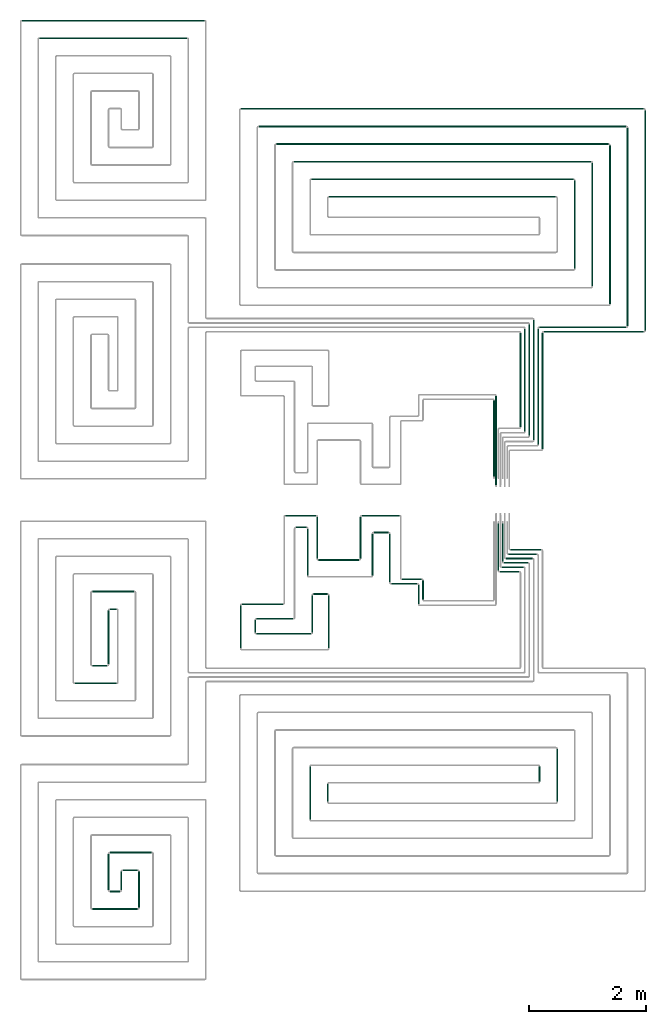
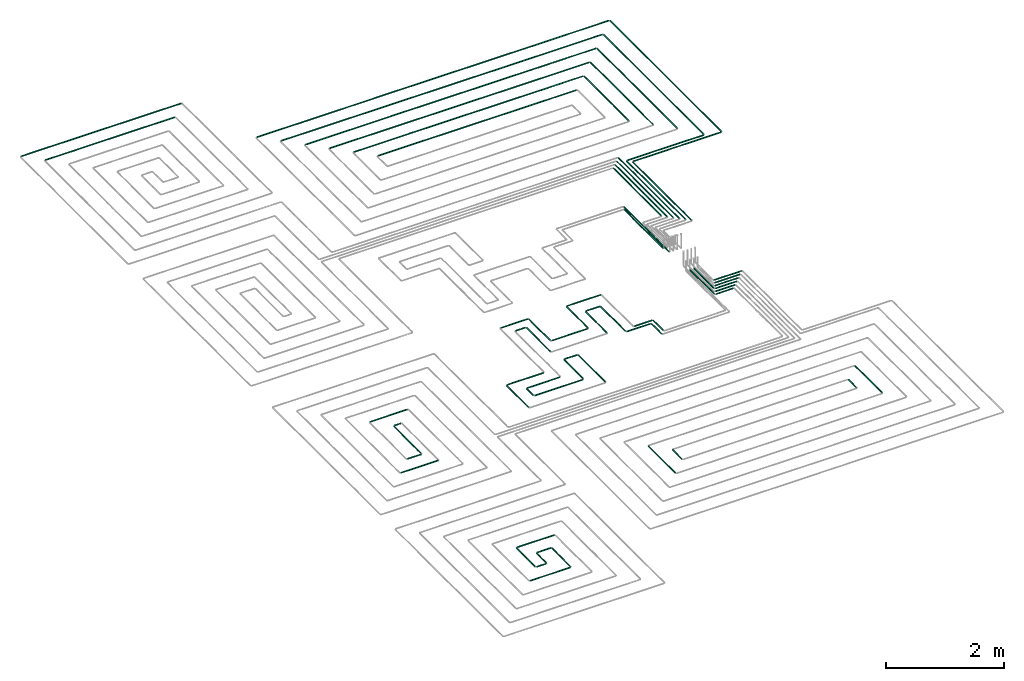
# One storey, part 3 of 12: 69 flow segments.
"""IFC2X3 building model written with IfcOpenShell, lengths in millimetres."""

from ifc_helpers import new_model, entity, si_unit, converted_unit, derived_unit, direction, frame, frame_2d, origin, origin_2d_with_axis, place, context, subcontext, project, spatial, circle, extrude, type_object, element, save


model = new_model("IFC2X3")

# Units and contexts
model_context = context("Model", 3, precision=0.01, world=origin(), true_north=direction((6.12303176911189e-17, 1.0)))
body_context = subcontext(model_context, "Body", "Model", "MODEL_VIEW")
ifc_project = project(units=[si_unit("LENGTHUNIT", "METRE", prefix="MILLI"), si_unit("AREAUNIT", "SQUARE_METRE"), si_unit("VOLUMEUNIT", "CUBIC_METRE"), converted_unit("PLANEANGLEUNIT", "DEGREE", entity("IfcRatioMeasure", 0.0174532925199433), si_unit("PLANEANGLEUNIT", "RADIAN"), dimensions=[0, 0, 0, 0, 0, 0, 0]), si_unit("MASSUNIT", "GRAM", prefix="KILO"), derived_unit("MASSDENSITYUNIT", [(si_unit("MASSUNIT", "GRAM", prefix="KILO"), 1), (si_unit("LENGTHUNIT", "METRE"), -3)]), si_unit("TIMEUNIT", "SECOND"), si_unit("FREQUENCYUNIT", "HERTZ"), si_unit("THERMODYNAMICTEMPERATUREUNIT", "DEGREE_CELSIUS"), derived_unit("THERMALTRANSMITTANCEUNIT", [(si_unit("MASSUNIT", "GRAM", prefix="KILO"), 1), (si_unit("THERMODYNAMICTEMPERATUREUNIT", "KELVIN"), -1), (si_unit("TIMEUNIT", "SECOND"), -3)]), derived_unit("VOLUMETRICFLOWRATEUNIT", [(si_unit("LENGTHUNIT", "METRE"), 3), (si_unit("TIMEUNIT", "SECOND"), -1)]), si_unit("ELECTRICCURRENTUNIT", "AMPERE"), si_unit("ELECTRICVOLTAGEUNIT", "VOLT"), si_unit("POWERUNIT", "WATT"), si_unit("FORCEUNIT", "NEWTON", prefix="KILO"), si_unit("ILLUMINANCEUNIT", "LUX"), si_unit("LUMINOUSFLUXUNIT", "LUMEN"), si_unit("LUMINOUSINTENSITYUNIT", "CANDELA"), derived_unit("USERDEFINED", [(si_unit("MASSUNIT", "GRAM", prefix="KILO"), -1), (si_unit("LENGTHUNIT", "METRE"), -2), (si_unit("TIMEUNIT", "SECOND"), 3), (si_unit("LUMINOUSFLUXUNIT", "LUMEN"), 1)]), derived_unit("LINEARVELOCITYUNIT", [(si_unit("LENGTHUNIT", "METRE"), 1), (si_unit("TIMEUNIT", "SECOND"), -1)]), si_unit("PRESSUREUNIT", "PASCAL"), derived_unit("USERDEFINED", [(si_unit("LENGTHUNIT", "METRE"), -2), (si_unit("MASSUNIT", "GRAM", prefix="KILO"), 1), (si_unit("TIMEUNIT", "SECOND"), -2)])], contexts=[model_context])

# Site, building, storey
site_placement = place(None, origin())
site = spatial("IfcSite", under=ifc_project, at=site_placement, CompositionType="ELEMENT")
building_placement = place(site_placement, origin())
building = spatial("IfcBuilding", under=site, at=building_placement, CompositionType="ELEMENT")
storey_placement = place(building_placement, frame((0.0, 0.0, 12000.0)))
storey = spatial("IfcBuildingStorey", under=building, at=storey_placement, Name="03 Level", CompositionType="ELEMENT", Elevation=12000.0)

# Flow segments
pipe_segment_type = type_object("IfcPipeSegmentType", PredefinedType="NOTDEFINED")
flow_segment_1_placement = place(storey_placement, frame((24021.0090559391, -70269.05691443, -81.5952722359252)))
element("IfcFlowSegment", 1, at=flow_segment_1_placement, inside=storey, type_object=pipe_segment_type, context=body_context, shape_type="SweptSolid", body=[
    extrude(circle(Radius=10.0, at=frame_2d((8.66293703438714e-12, -2.16573425859679e-12), x_axis=(1.0, 0.0))), frame((0.0, 11.5952722359136, 11.595272235918), z_axis=(1.0, 0.0, 0.0), x_axis=(0.0, 1.0, 0.0)), (0.0, 0.0, 1.0), 450.721832403925),
])
flow_segment_2_placement = place(storey_placement, frame((18625.6253473194, -71966.1931086591, -81.5952722359234)))
element("IfcFlowSegment", 2, at=flow_segment_2_placement, inside=storey, type_object=pipe_segment_type, context=body_context, shape_type="SweptSolid", body=[
    extrude(circle(Radius=10.0, at=origin_2d_with_axis()), frame((0.0, 11.5952722359136, 11.5952722359158), z_axis=(1.0, 0.0, 0.0), x_axis=(0.0, 1.0, 0.0)), (0.0, 0.0, 1.0), 718.813282054726),
])
flow_segment_3_placement = place(storey_placement, frame((18925.6253473194, -70402.8348573758, -81.5952722359234)))
element("IfcFlowSegment", 3, at=flow_segment_3_placement, inside=storey, type_object=pipe_segment_type, context=body_context, shape_type="SweptSolid", body=[
    extrude(circle(Radius=10.0, at=origin_2d_with_axis()), frame((0.0, 11.5952722359136, 11.5952722359158), z_axis=(1.0, 0.0, 0.0), x_axis=(0.0, -1.0, 0.0)), (0.0, 0.0, 1.0), 718.813282054721),
])
flow_segment_4_placement = place(storey_placement, frame((19225.6253473194, -70702.8348573758, -81.5952722359234)))
element("IfcFlowSegment", 4, at=flow_segment_4_placement, inside=storey, type_object=pipe_segment_type, context=body_context, shape_type="SweptSolid", body=[
    extrude(circle(Radius=10.0, at=frame_2d((-8.66293703438714e-12, 0.0), x_axis=(1.0, 0.0))), frame((0.0, 11.5952722359136, 11.5952722359158), z_axis=(1.0, 0.0, 0.0), x_axis=(0.0, 1.0, 0.0)), (0.0, 0.0, 1.0), 118.813282054734),
])
flow_segment_5_placement = place(storey_placement, frame((19194.0300750835, -71634.5978364232, -81.5952722359234)))
element("IfcFlowSegment", 5, at=flow_segment_5_placement, inside=storey, type_object=pipe_segment_type, context=body_context, shape_type="SweptSolid", body=[
    extrude(circle(Radius=10.0, at=frame_2d((-2.16573425859679e-12, 0.0), x_axis=(1.0, 0.0))), frame((11.595272235918, 0.0, 11.5952722359158), z_axis=(0.0, 1.0, 0.0), x_axis=(-1.0, 0.0, 0.0)), (0.0, 0.0, 1.0), 923.358251283313),
])
flow_segment_6_placement = place(storey_placement, frame((18925.6253473194, -71666.1931086591, -81.595272235927)))
element("IfcFlowSegment", 6, at=flow_segment_6_placement, inside=storey, type_object=pipe_segment_type, context=body_context, shape_type="SweptSolid", body=[
    extrude(circle(Radius=10.0, at=frame_2d((8.66293703438714e-12, 0.0), x_axis=(1.0, 0.0))), frame((0.0, 11.5952722359136, 11.5952722359158), z_axis=(1.0, 0.0, 0.0), x_axis=(0.0, 1.0, 0.0)), (0.0, 0.0, 1.0), 260.000000000012),
])
flow_segment_7_placement = place(storey_placement, frame((19712.8433571382, -75784.5978364232, -81.5952722359252)))
element("IfcFlowSegment", 7, at=flow_segment_7_placement, inside=storey, type_object=pipe_segment_type, context=body_context, shape_type="SweptSolid", body=[
    extrude(circle(Radius=10.0, at=frame_2d((-8.66293703438714e-12, -2.16573425859679e-12), x_axis=(1.0, 0.0))), frame((11.5952722359266, 0.0, 11.595272235918), z_axis=(0.0, 1.0, 0.0), x_axis=(-1.0, 0.0, 0.0)), (0.0, 0.0, 1.0), 623.358251283277),
])
flow_segment_8_placement = place(storey_placement, frame((19412.8433571382, -75484.5978364232, -81.595272235927)))
element("IfcFlowSegment", 8, at=flow_segment_8_placement, inside=storey, type_object=pipe_segment_type, context=body_context, shape_type="SweptSolid", body=[
    extrude(circle(Radius=10.0, at=frame_2d((6.49720277579036e-12, 0.0), x_axis=(1.0, 0.0))), frame((11.5952722359223, 0.0, 11.5952722359158), z_axis=(0.0, 1.0, 0.0), x_axis=(-1.0, 0.0, 0.0)), (0.0, 0.0, 1.0), 323.358251283363),
])
flow_segment_9_placement = place(storey_placement, frame((19194.0300750835, -75484.5978364232, -81.5952722359252)))
element("IfcFlowSegment", 9, at=flow_segment_9_placement, inside=storey, type_object=pipe_segment_type, context=body_context, shape_type="SweptSolid", body=[
    extrude(circle(Radius=10.0, at=frame_2d((-6.49720277579036e-12, -2.16573425859679e-12), x_axis=(1.0, 0.0))), frame((11.5952722359223, 0.0, 11.595272235918), z_axis=(0.0, 1.0, 0.0), x_axis=(-1.0, 0.0, 0.0)), (0.0, 0.0, 1.0), 623.358251283355),
])
flow_segment_10_placement = place(storey_placement, frame((19225.6253473194, -74852.8348573758, -81.5952722359216)))
element("IfcFlowSegment", 10, at=flow_segment_10_placement, inside=storey, type_object=pipe_segment_type, context=body_context, shape_type="SweptSolid", body=[
    extrude(circle(Radius=10.0, at=frame_2d((-2.59888111031614e-11, 0.0), x_axis=(1.0, 0.0))), frame((0.0, 11.5952722359396, 11.5952722359158), z_axis=(1.0, 0.0, 0.0), x_axis=(0.0, 1.0, 0.0)), (0.0, 0.0, 1.0), 718.813282054736),
])
flow_segment_11_placement = place(storey_placement, frame((18925.6253473194, -75816.1931086591, -81.5952722359252)))
element("IfcFlowSegment", 11, at=flow_segment_11_placement, inside=storey, type_object=pipe_segment_type, context=body_context, shape_type="SweptSolid", body=[
    extrude(circle(Radius=10.0, at=frame_2d((3.46517481375486e-11, -2.16573425859679e-12), x_axis=(1.0, 0.0))), frame((0.0, 11.595272235931, 11.595272235918), z_axis=(1.0, 0.0, 0.0), x_axis=(0.0, 1.0, 0.0)), (0.0, 0.0, 1.0), 778.813282054757),
])
flow_segment_12_placement = place(storey_placement, frame((19225.6253473194, -75516.1931086591, -81.595272235927)))
element("IfcFlowSegment", 12, at=flow_segment_12_placement, inside=storey, type_object=pipe_segment_type, context=body_context, shape_type="SweptSolid", body=[
    extrude(circle(Radius=10.0, at=origin_2d_with_axis()), frame((0.0, 11.5952722359136, 11.5952722359158), z_axis=(1.0, 0.0, 0.0), x_axis=(0.0, 1.0, 0.0)), (0.0, 0.0, 1.0), 178.813282054764),
])
flow_segment_13_placement = place(storey_placement, frame((19444.4386293741, -75152.8348573758, -81.5952722359252)))
element("IfcFlowSegment", 13, at=flow_segment_13_placement, inside=storey, type_object=pipe_segment_type, context=body_context, shape_type="SweptSolid", body=[
    extrude(circle(Radius=10.0, at=frame_2d((-8.66293703438714e-12, -2.16573425859679e-12), x_axis=(1.0, 0.0))), frame((0.0, 11.595272235931, 11.595272235918), z_axis=(1.0, 0.0, 0.0), x_axis=(0.0, 1.0, 0.0)), (0.0, 0.0, 1.0), 260.000000000017),
])
flow_segment_14_placement = place(storey_placement, frame((26841.5018091839, -73979.8436457933, -81.5952722359216)))
element("IfcFlowSegment", 14, at=flow_segment_14_placement, inside=storey, type_object=pipe_segment_type, context=body_context, shape_type="SweptSolid", body=[
    extrude(circle(Radius=10.0, at=frame_2d((-8.66293703438714e-12, 0.0), x_axis=(1.0, 0.0))), frame((11.5952722359266, 0.0, 11.5952722359158), z_axis=(0.0, 1.0, 0.0), x_axis=(-1.0, 0.0, 0.0)), (0.0, 0.0, 1.0), 907.858932130948),
])
flow_segment_15_placement = place(storey_placement, frame((22930.6562350406, -73979.8436457933, -81.5952722359325)))
element("IfcFlowSegment", 15, at=flow_segment_15_placement, inside=storey, type_object=pipe_segment_type, context=body_context, shape_type="SweptSolid", body=[
    extrude(circle(Radius=10.0, at=frame_2d((-4.33146851719357e-12, 0.0), x_axis=(1.0, 0.0))), frame((11.5952722359223, 0.0, 11.5952722359158), z_axis=(0.0, 1.0, 0.0), x_axis=(-1.0, 0.0, 0.0)), (0.0, 0.0, 1.0), 307.858932131015),
])
flow_segment_16_placement = place(storey_placement, frame((22630.6562350406, -74279.8436457932, -81.5952722359325)))
element("IfcFlowSegment", 16, at=flow_segment_16_placement, inside=storey, type_object=pipe_segment_type, context=body_context, shape_type="SweptSolid", body=[
    extrude(circle(Radius=10.0, at=frame_2d((-1.29944055515807e-11, 0.0), x_axis=(1.0, 0.0))), frame((11.595272235931, 0.0, 11.5952722359158), z_axis=(0.0, 1.0, 0.0), x_axis=(-1.0, 0.0, 0.0)), (0.0, 0.0, 1.0), 907.858932131),
])
flow_segment_17_placement = place(storey_placement, frame((26541.5018091839, -73631.9847136623, -81.5952722359252)))
element("IfcFlowSegment", 17, at=flow_segment_17_placement, inside=storey, type_object=pipe_segment_type, context=body_context, shape_type="SweptSolid", body=[
    extrude(circle(Radius=10.0, at=frame_2d((-4.33146851719357e-12, -2.16573425859679e-12), x_axis=(1.0, 0.0))), frame((11.5952722359223, 0.0, 11.595272235918), z_axis=(0.0, 1.0, 0.0), x_axis=(-1.0, 0.0, 0.0)), (0.0, 0.0, 1.0), 260.000000000019),
])
flow_segment_18_placement = place(storey_placement, frame((23989.4137837031, -70237.4616421941, -81.5952722359216)))
element("IfcFlowSegment", 18, at=flow_segment_18_placement, inside=storey, type_object=pipe_segment_type, context=body_context, shape_type="SweptSolid", body=[
    extrude(circle(Radius=10.0, at=frame_2d((-3.0320279620355e-11, 0.0), x_axis=(1.0, 0.0))), frame((11.5952722359439, 0.0, 11.5952722359158), z_axis=(0.0, 1.0, 0.0), x_axis=(-1.0, 0.0, 0.0)), (0.0, 0.0, 1.0), 831.830711127864),
])
flow_segment_19_placement = place(storey_placement, frame((22221.748982204, -69109.6350508284, -81.5952722359325)))
element("IfcFlowSegment", 19, at=flow_segment_19_placement, inside=storey, type_object=pipe_segment_type, context=body_context, shape_type="SweptSolid", body=[
    extrude(circle(Radius=10.0, at=frame_2d((-8.66293703438714e-12, 0.0), x_axis=(1.0, 0.0))), frame((0.0, 11.5952722359223, 11.5952722359158), z_axis=(1.0, 0.0, 0.0), x_axis=(0.0, 1.0, 0.0)), (0.0, 0.0, 1.0), 520.399525361204),
])
flow_segment_20_placement = place(storey_placement, frame((22396.748982204, -69309.6350508284, -81.5952722359234)))
element("IfcFlowSegment", 20, at=flow_segment_20_placement, inside=storey, type_object=pipe_segment_type, context=body_context, shape_type="SweptSolid", body=[
    extrude(circle(Radius=10.0, at=origin_2d_with_axis()), frame((0.0, 11.5952722359136, 11.5952722359158), z_axis=(1.0, 0.0, 0.0), x_axis=(0.0, 1.0, 0.0)), (0.0, 0.0, 1.0), 185.39952536122),
])
flow_segment_21_placement = place(storey_placement, frame((21695.3876311493, -71092.3249584181, -81.5952722359252)))
element("IfcFlowSegment", 21, at=flow_segment_21_placement, inside=storey, type_object=pipe_segment_type, context=body_context, shape_type="SweptSolid", body=[
    extrude(circle(Radius=10.0, at=frame_2d((0.0, -2.16573425859679e-12), x_axis=(1.0, 0.0))), frame((11.595272235918, 0.0, 11.595272235918), z_axis=(0.0, 1.0, 0.0), x_axis=(-1.0, 0.0, 0.0)), (0.0, 0.0, 1.0), 216.085373278228),
])
flow_segment_22_placement = place(storey_placement, frame((21445.3876311493, -71362.3249584181, -81.595272235927)))
element("IfcFlowSegment", 22, at=flow_segment_22_placement, inside=storey, type_object=pipe_segment_type, context=body_context, shape_type="SweptSolid", body=[
    extrude(circle(Radius=10.0, at=frame_2d((-1.73258740687743e-11, 0.0), x_axis=(1.0, 0.0))), frame((11.5952722359266, 0.0, 11.5952722359158), z_axis=(0.0, 1.0, 0.0), x_axis=(-1.0, 0.0, 0.0)), (0.0, 0.0, 1.0), 736.085373278231),
])
flow_segment_23_placement = place(storey_placement, frame((21726.9829033853, -71123.9202306541, -81.595272235927)))
element("IfcFlowSegment", 23, at=flow_segment_23_placement, inside=storey, type_object=pipe_segment_type, context=body_context, shape_type="SweptSolid", body=[
    extrude(circle(Radius=10.0, at=frame_2d((-8.66293703438714e-12, 0.0), x_axis=(1.0, 0.0))), frame((0.0, 11.5952722359136, 11.5952722359158), z_axis=(1.0, 0.0, 0.0), x_axis=(0.0, 1.0, 0.0)), (0.0, 0.0, 1.0), 931.77751147485),
])
flow_segment_24_placement = place(storey_placement, frame((21476.9829033853, -70617.8348573758, -81.5952722359252)))
element("IfcFlowSegment", 24, at=flow_segment_24_placement, inside=storey, type_object=pipe_segment_type, context=body_context, shape_type="SweptSolid", body=[
    extrude(circle(Radius=10.0, at=frame_2d((-8.66293703438714e-12, -2.16573425859679e-12), x_axis=(1.0, 0.0))), frame((0.0, 11.5952722359223, 11.595272235918), z_axis=(1.0, 0.0, 0.0), x_axis=(0.0, 1.0, 0.0)), (0.0, 0.0, 1.0), 704.766078818666),
])
flow_segment_25_placement = place(storey_placement, frame((21726.9829033853, -70867.8348573759, -81.5952722359234)))
element("IfcFlowSegment", 25, at=flow_segment_25_placement, inside=storey, type_object=pipe_segment_type, context=body_context, shape_type="SweptSolid", body=[
    extrude(circle(Radius=10.0, at=frame_2d((-8.66293703438714e-12, 0.0), x_axis=(1.0, 0.0))), frame((0.0, 11.595272235931, 11.5952722359158), z_axis=(1.0, 0.0, 0.0), x_axis=(0.0, 1.0, 0.0)), (0.0, 0.0, 1.0), 629.766078818679),
])
flow_segment_26_placement = place(storey_placement, frame((22667.1651426242, -71092.3249584181, -81.5952722359343)))
element("IfcFlowSegment", 26, at=flow_segment_26_placement, inside=storey, type_object=pipe_segment_type, context=body_context, shape_type="SweptSolid", body=[
    extrude(circle(Radius=10.0, at=frame_2d((-4.33146851719357e-12, -2.16573425859679e-12), x_axis=(1.0, 0.0))), frame((11.595272235918, 0.0, 11.595272235918), z_axis=(0.0, 1.0, 0.0), x_axis=(-1.0, 0.0, 0.0)), (0.0, 0.0, 1.0), 638.585373278218),
])
flow_segment_27_placement = place(storey_placement, frame((22947.1651426242, -71362.3249584182, -81.5952722359289)))
element("IfcFlowSegment", 27, at=flow_segment_27_placement, inside=storey, type_object=pipe_segment_type, context=body_context, shape_type="SweptSolid", body=[
    extrude(circle(Radius=10.0, at=frame_2d((-4.33146851719357e-12, 0.0), x_axis=(1.0, 0.0))), frame((11.5952722359223, 0.0, 11.5952722359158), z_axis=(0.0, 1.0, 0.0), x_axis=(-1.0, 0.0, 0.0)), (0.0, 0.0, 1.0), 908.585373278235),
])
flow_segment_28_placement = place(storey_placement, frame((22698.7604148601, -70445.3348573758, -81.595272235927)))
element("IfcFlowSegment", 28, at=flow_segment_28_placement, inside=storey, type_object=pipe_segment_type, context=body_context, shape_type="SweptSolid", body=[
    extrude(circle(Radius=10.0, at=origin_2d_with_axis()), frame((0.0, 11.5952722359136, 11.5952722359158), z_axis=(1.0, 0.0, 0.0), x_axis=(0.0, 1.0, 0.0)), (0.0, 0.0, 1.0), 239.999999999976),
])
flow_segment_29_placement = place(storey_placement, frame((25981.0369719708, -69840.3348573759, -81.5952722359289)))
element("IfcFlowSegment", 29, at=flow_segment_29_placement, inside=storey, type_object=pipe_segment_type, context=body_context, shape_type="SweptSolid", body=[
    extrude(circle(Radius=10.0, at=frame_2d((0.0, -2.16573425859679e-12), x_axis=(1.0, 0.0))), frame((0.0, 11.5952722359136, 11.5952722359136), z_axis=(1.0, 0.0, 0.0), x_axis=(0.0, -1.0, 0.0)), (0.0, 0.0, 1.0), 452.648577476757),
])
flow_segment_30_placement = place(storey_placement, frame((25946.0369719708, -69915.3348573758, -81.5952722359325)))
element("IfcFlowSegment", 30, at=flow_segment_30_placement, inside=storey, type_object=pipe_segment_type, context=body_context, shape_type="SweptSolid", body=[
    extrude(circle(Radius=10.0, at=origin_2d_with_axis()), frame((0.0, 11.5952722359223, 11.5952722359158), z_axis=(1.0, 0.0, 0.0), x_axis=(0.0, -1.0, 0.0)), (0.0, 0.0, 1.0), 412.648577476762),
])
flow_segment_31_placement = place(storey_placement, frame((25906.0369719708, -69990.3348573758, -81.5952722359289)))
element("IfcFlowSegment", 31, at=flow_segment_31_placement, inside=storey, type_object=pipe_segment_type, context=body_context, shape_type="SweptSolid", body=[
    extrude(circle(Radius=10.0, at=frame_2d((0.0, -2.16573425859679e-12), x_axis=(1.0, 0.0))), frame((0.0, 11.5952722359223, 11.5952722359136), z_axis=(1.0, 0.0, 0.0), x_axis=(0.0, -1.0, 0.0)), (0.0, 0.0, 1.0), 377.648577476765),
])
flow_segment_32_placement = place(storey_placement, frame((25871.0369719708, -70065.3348573758, -81.5952722359289)))
element("IfcFlowSegment", 32, at=flow_segment_32_placement, inside=storey, type_object=pipe_segment_type, context=body_context, shape_type="SweptSolid", body=[
    extrude(circle(Radius=10.0, at=frame_2d((0.0, -2.16573425859679e-12), x_axis=(1.0, 0.0))), frame((0.0, 11.5952722359136, 11.5952722359136), z_axis=(1.0, 0.0, 0.0), x_axis=(0.0, -1.0, 0.0)), (0.0, 0.0, 1.0), 337.64857747677),
])
flow_segment_33_placement = place(storey_placement, frame((26056.0369719708, -69690.3348573759, -81.5952722359325)))
element("IfcFlowSegment", 33, at=flow_segment_33_placement, inside=storey, type_object=pipe_segment_type, context=body_context, shape_type="SweptSolid", body=[
    extrude(circle(Radius=10.0, at=origin_2d_with_axis()), frame((0.0, 11.5952722359136, 11.5952722359158), z_axis=(1.0, 0.0, 0.0), x_axis=(0.0, -1.0, 0.0)), (0.0, 0.0, 1.0), 527.648577476736),
])
flow_segment_34_placement = place(storey_placement, frame((26021.0369719708, -69765.3348573759, -81.5952722359289)))
element("IfcFlowSegment", 34, at=flow_segment_34_placement, inside=storey, type_object=pipe_segment_type, context=body_context, shape_type="SweptSolid", body=[
    extrude(circle(Radius=10.0, at=frame_2d((0.0, -2.16573425859679e-12), x_axis=(1.0, 0.0))), frame((0.0, 11.5952722359136, 11.5952722359136), z_axis=(1.0, 0.0, 0.0), x_axis=(0.0, -1.0, 0.0)), (0.0, 0.0, 1.0), 487.648577476745),
])
flow_segment_35_placement = place(storey_placement, frame((25839.4416997349, -70033.7395851399, -81.5952722359289)))
element("IfcFlowSegment", 35, at=flow_segment_35_placement, inside=storey, type_object=pipe_segment_type, context=body_context, shape_type="SweptSolid", body=[
    extrude(circle(Radius=10.0, at=frame_2d((0.0, -2.16573425859679e-12), x_axis=(1.0, 0.0))), frame((11.595272235918, 0.0, 11.5952722359136), z_axis=(0.0, 1.0, 0.0), x_axis=(1.0, 0.0, 0.0)), (0.0, 0.0, 1.0), 807.49999999999),
])
flow_segment_36_placement = place(storey_placement, frame((25914.4416997349, -69883.7395851399, -81.5952722359325)))
element("IfcFlowSegment", 36, at=flow_segment_36_placement, inside=storey, type_object=pipe_segment_type, context=body_context, shape_type="SweptSolid", body=[
    extrude(circle(Radius=10.0, at=origin_2d_with_axis()), frame((11.595272235918, 0.0, 11.5952722359158), z_axis=(0.0, 1.0, 0.0), x_axis=(1.0, 0.0, 0.0)), (0.0, 0.0, 1.0), 657.499999999989),
])
flow_segment_37_placement = place(storey_placement, frame((24206.0090559391, -70194.0569144301, -81.5952722359289)))
element("IfcFlowSegment", 37, at=flow_segment_37_placement, inside=storey, type_object=pipe_segment_type, context=body_context, shape_type="SweptSolid", body=[
    extrude(circle(Radius=10.0, at=frame_2d((1.73258740687743e-11, 0.0), x_axis=(1.0, 0.0))), frame((0.0, 11.595272235931, 11.5952722359158), z_axis=(1.0, 0.0, 0.0), x_axis=(0.0, 1.0, 0.0)), (0.0, 0.0, 1.0), 340.721832403933),
])
flow_segment_38_placement = place(storey_placement, frame((24480.1356161071, -70606.3143518619, -81.5952722359252)))
element("IfcFlowSegment", 38, at=flow_segment_38_placement, inside=storey, type_object=pipe_segment_type, context=body_context, shape_type="SweptSolid", body=[
    extrude(circle(Radius=10.0, at=frame_2d((-8.66293703438714e-12, -2.16573425859679e-12), x_axis=(1.0, 0.0))), frame((11.595272235918, 0.0, 11.595272235918), z_axis=(0.0, 1.0, 0.0), x_axis=(-1.0, 0.0, 0.0)), (0.0, 0.0, 1.0), 328.852709667764),
])
flow_segment_39_placement = place(storey_placement, frame((24555.1356161071, -70531.3143518619, -81.595272235927)))
element("IfcFlowSegment", 39, at=flow_segment_39_placement, inside=storey, type_object=pipe_segment_type, context=body_context, shape_type="SweptSolid", body=[
    extrude(circle(Radius=10.0, at=origin_2d_with_axis()), frame((11.595272235918, 0.0, 11.5952722359158), z_axis=(0.0, 1.0, 0.0), x_axis=(1.0, 0.0, 0.0)), (0.0, 0.0, 1.0), 328.852709667773),
])
flow_segment_40_placement = place(storey_placement, frame((22590.5532353292, -70121.2395851399, -81.5952722359234)))
element("IfcFlowSegment", 40, at=flow_segment_40_placement, inside=storey, type_object=pipe_segment_type, context=body_context, shape_type="SweptSolid", body=[
    extrude(circle(Radius=10.0, at=frame_2d((-2.16573425859679e-11, 0.0), x_axis=(1.0, 0.0))), frame((11.5952722359439, 0.0, 11.5952722359158), z_axis=(0.0, 1.0, 0.0), x_axis=(-1.0, 0.0, 0.0)), (0.0, 0.0, 1.0), 803.199806547433),
])
flow_segment_41_placement = place(storey_placement, frame((22750.5532353292, -69833.6484326662, -81.5952722359325)))
element("IfcFlowSegment", 41, at=flow_segment_41_placement, inside=storey, type_object=pipe_segment_type, context=body_context, shape_type="SweptSolid", body=[
    extrude(circle(Radius=10.0, at=frame_2d((-2.16573425859679e-11, 0.0), x_axis=(1.0, 0.0))), frame((11.5952722359396, 0.0, 11.5952722359158), z_axis=(0.0, 1.0, 0.0), x_axis=(-1.0, 0.0, 0.0)), (0.0, 0.0, 1.0), 715.608654073691),
])
flow_segment_42_placement = place(storey_placement, frame((23519.956152799, -69109.6350508284, -81.5952722359325)))
element("IfcFlowSegment", 42, at=flow_segment_42_placement, inside=storey, type_object=pipe_segment_type, context=body_context, shape_type="SweptSolid", body=[
    extrude(circle(Radius=10.0, at=origin_2d_with_axis()), frame((0.0, 11.5952722359396, 11.5952722359158), z_axis=(1.0, 0.0, 0.0), x_axis=(0.0, -1.0, 0.0)), (0.0, 0.0, 1.0), 646.052903140118),
])
flow_segment_43_placement = place(storey_placement, frame((23724.956152799, -69397.2262033022, -81.5952722359216)))
element("IfcFlowSegment", 43, at=flow_segment_43_placement, inside=storey, type_object=pipe_segment_type, context=body_context, shape_type="SweptSolid", body=[
    extrude(circle(Radius=10.0, at=frame_2d((0.0, -2.16573425859679e-12), x_axis=(1.0, 0.0))), frame((0.0, 11.595272235931, 11.5952722359136), z_axis=(1.0, 0.0, 0.0), x_axis=(0.0, -1.0, 0.0)), (0.0, 0.0, 1.0), 256.052903140129),
])
for number, where in (
    (44, (23488.3608805631, -69833.6484326662, -81.5952722359325)),
    (45, (23693.360880563, -70121.2395851399, -81.5952722359234)),
):
    element("IfcFlowSegment", number, at=place(storey_placement, frame(where)), inside=storey, type_object=pipe_segment_type, context=body_context, shape_type="SweptSolid", body=[
        extrude(circle(Radius=10.0, at=frame_2d((-1.29944055515807e-11, 0.0), x_axis=(1.0, 0.0))), frame((11.595272235931, 0.0, 11.5952722359158), z_axis=(0.0, 1.0, 0.0), x_axis=(-1.0, 0.0, 0.0)), (0.0, 0.0, 1.0), 715.608654073717),
    ])
flow_segment_44_placement = place(storey_placement, frame((22782.1485075651, -69865.2437049021, -81.5952722359289)))
element("IfcFlowSegment", 46, at=flow_segment_44_placement, inside=storey, type_object=pipe_segment_type, context=body_context, shape_type="SweptSolid", body=[
    extrude(circle(Radius=10.0, at=frame_2d((-8.66293703438714e-12, 0.0), x_axis=(1.0, 0.0))), frame((0.0, 11.5952722359223, 11.5952722359158), z_axis=(1.0, 0.0, 0.0), x_axis=(0.0, 1.0, 0.0)), (0.0, 0.0, 1.0), 697.807645233866),
])
flow_segment_45_placement = place(storey_placement, frame((18025.6253473194, -60969.4766060926, -81.5952722359198)))
element("IfcFlowSegment", 47, at=flow_segment_45_placement, inside=storey, type_object=pipe_segment_type, context=body_context, shape_type="SweptSolid", body=[
    extrude(circle(Radius=10.0, at=frame_2d((-8.66293703438714e-12, 0.0), x_axis=(1.0, 0.0))), frame((0.0, 11.5952722359136, 11.5952722359158), z_axis=(1.0, 0.0, 0.0), x_axis=(0.0, 1.0, 0.0)), (0.0, 0.0, 1.0), 2518.8132820547),
])
flow_segment_46_placement = place(storey_placement, frame((17725.6253473194, -60669.4766060926, -81.5952722359161)))
element("IfcFlowSegment", 48, at=flow_segment_46_placement, inside=storey, type_object=pipe_segment_type, context=body_context, shape_type="SweptSolid", body=[
    extrude(circle(Radius=10.0, at=frame_2d((8.66293703438714e-12, -2.16573425859679e-12), x_axis=(1.0, 0.0))), frame((0.0, 11.5952722359136, 11.595272235918), z_axis=(1.0, 0.0, 0.0), x_axis=(0.0, 1.0, 0.0)), (0.0, 0.0, 1.0), 3118.81328205468),
])
flow_segment_47_placement = place(storey_placement, frame((26623.6855494475, -65974.0247077234, -81.5952722359161)))
element("IfcFlowSegment", 49, at=flow_segment_47_placement, inside=storey, type_object=pipe_segment_type, context=body_context, shape_type="SweptSolid", body=[
    extrude(circle(Radius=10.0, at=origin_2d_with_axis()), frame((0.0, 11.5952722359483, 11.5952722359158), z_axis=(1.0, 0.0, 0.0), x_axis=(0.0, -1.0, 0.0)), (0.0, 0.0, 1.0), 1709.41153197237),
])
flow_segment_48_placement = place(storey_placement, frame((26548.6855494475, -65899.0247077234, -81.5952722359143)))
element("IfcFlowSegment", 50, at=flow_segment_48_placement, inside=storey, type_object=pipe_segment_type, context=body_context, shape_type="SweptSolid", body=[
    extrude(circle(Radius=10.0, at=origin_2d_with_axis()), frame((0.0, 11.5952722359483, 11.5952722359158), z_axis=(1.0, 0.0, 0.0), x_axis=(0.0, -1.0, 0.0)), (0.0, 0.0, 1.0), 1484.41153197236),
])
flow_segment_49_placement = place(storey_placement, frame((28341.5018091839, -65942.4294354875, -81.5952722359161)))
element("IfcFlowSegment", 51, at=flow_segment_49_placement, inside=storey, type_object=pipe_segment_type, context=body_context, shape_type="SweptSolid", body=[
    extrude(circle(Radius=10.0, at=frame_2d((2.59888111031614e-11, -2.16573425859679e-12), x_axis=(1.0, 0.0))), frame((11.5952722359439, 0.0, 11.595272235918), z_axis=(0.0, 1.0, 0.0), x_axis=(-1.0, 0.0, 0.0)), (0.0, 0.0, 1.0), 3759.79391100087),
])
flow_segment_50_placement = place(storey_placement, frame((28041.5018091839, -65867.4294354875, -81.5952722359198)))
element("IfcFlowSegment", 52, at=flow_segment_50_placement, inside=storey, type_object=pipe_segment_type, context=body_context, shape_type="SweptSolid", body=[
    extrude(circle(Radius=10.0, at=origin_2d_with_axis()), frame((11.5952722359613, 0.0, 11.5952722359158), z_axis=(0.0, 1.0, 0.0), x_axis=(1.0, 0.0, 0.0)), (0.0, 0.0, 1.0), 3384.79391100087),
])
flow_segment_51_placement = place(storey_placement, frame((27741.5018091839, -65490.4944566175, -81.5952722359198)))
element("IfcFlowSegment", 53, at=flow_segment_51_placement, inside=storey, type_object=pipe_segment_type, context=body_context, shape_type="SweptSolid", body=[
    extrude(circle(Radius=10.0, at=frame_2d((2.16573425859679e-11, 0.0), x_axis=(1.0, 0.0))), frame((11.5952722359439, 0.0, 11.5952722359158), z_axis=(0.0, 1.0, 0.0), x_axis=(-1.0, 0.0, 0.0)), (0.0, 0.0, 1.0), 2707.85893213088),
])
flow_segment_52_placement = place(storey_placement, frame((27441.501809184, -65190.4944566175, -81.5952722359161)))
element("IfcFlowSegment", 54, at=flow_segment_52_placement, inside=storey, type_object=pipe_segment_type, context=body_context, shape_type="SweptSolid", body=[
    extrude(circle(Radius=10.0, at=origin_2d_with_axis()), frame((11.5952722359439, 0.0, 11.5952722359158), z_axis=(0.0, 1.0, 0.0), x_axis=(1.0, 0.0, 0.0)), (0.0, 0.0, 1.0), 2107.85893213088),
])
flow_segment_53_placement = place(storey_placement, frame((21762.2515072766, -62474.2307967226, -81.595272235927)))
element("IfcFlowSegment", 55, at=flow_segment_53_placement, inside=storey, type_object=pipe_segment_type, context=body_context, shape_type="SweptSolid", body=[
    extrude(circle(Radius=10.0, at=origin_2d_with_axis()), frame((0.0, 11.5952722359136, 11.5952722359158), z_axis=(1.0, 0.0, 0.0), x_axis=(0.0, -1.0, 0.0)), (0.0, 0.0, 1.0), 6270.84557414324),
])
flow_segment_54_placement = place(storey_placement, frame((21462.2515072766, -62174.2307967226, -81.5952722359161)))
element("IfcFlowSegment", 56, at=flow_segment_54_placement, inside=storey, type_object=pipe_segment_type, context=body_context, shape_type="SweptSolid", body=[
    extrude(circle(Radius=10.0, at=frame_2d((0.0, -2.16573425859679e-12), x_axis=(1.0, 0.0))), frame((0.0, 11.5952722359136, 11.595272235918), z_axis=(1.0, 0.0, 0.0), x_axis=(0.0, 1.0, 0.0)), (0.0, 0.0, 1.0), 6870.84557414322),
])
flow_segment_55_placement = place(storey_placement, frame((22362.2515072766, -63074.2307967226, -81.5952722359216)))
element("IfcFlowSegment", 57, at=flow_segment_55_placement, inside=storey, type_object=pipe_segment_type, context=body_context, shape_type="SweptSolid", body=[
    extrude(circle(Radius=10.0, at=frame_2d((-8.66293703438714e-12, 0.0), x_axis=(1.0, 0.0))), frame((0.0, 11.5952722359223, 11.5952722359158), z_axis=(1.0, 0.0, 0.0), x_axis=(0.0, 1.0, 0.0)), (0.0, 0.0, 1.0), 5070.84557414327),
])
flow_segment_56_placement = place(storey_placement, frame((22062.2515072766, -62774.2307967226, -81.5952722359289)))
element("IfcFlowSegment", 58, at=flow_segment_56_placement, inside=storey, type_object=pipe_segment_type, context=body_context, shape_type="SweptSolid", body=[
    extrude(circle(Radius=10.0, at=frame_2d((0.0, -2.16573425859679e-12), x_axis=(1.0, 0.0))), frame((0.0, 11.5952722359136, 11.5952722359136), z_axis=(1.0, 0.0, 0.0), x_axis=(0.0, -1.0, 0.0)), (0.0, 0.0, 1.0), 5670.84557414326),
])
flow_segment_57_placement = place(storey_placement, frame((27141.501809184, -64890.4944566176, -81.5952722359216)))
element("IfcFlowSegment", 59, at=flow_segment_57_placement, inside=storey, type_object=pipe_segment_type, context=body_context, shape_type="SweptSolid", body=[
    extrude(circle(Radius=10.0, at=frame_2d((8.66293703438714e-12, 0.0), x_axis=(1.0, 0.0))), frame((11.5952722359266, 0.0, 11.5952722359158), z_axis=(0.0, 1.0, 0.0), x_axis=(-1.0, 0.0, 0.0)), (0.0, 0.0, 1.0), 1507.85893213094),
])
flow_segment_58_placement = place(storey_placement, frame((22962.2515072766, -63674.2307967225, -81.5952722359398)))
element("IfcFlowSegment", 60, at=flow_segment_58_placement, inside=storey, type_object=pipe_segment_type, context=body_context, shape_type="SweptSolid", body=[
    extrude(circle(Radius=10.0, at=origin_2d_with_axis()), frame((0.0, 11.5952722359223, 11.5952722359158), z_axis=(1.0, 0.0, 0.0), x_axis=(0.0, -1.0, 0.0)), (0.0, 0.0, 1.0), 3870.84557414329),
])
flow_segment_59_placement = place(storey_placement, frame((22662.2515072766, -63374.2307967225, -81.5952722359325)))
element("IfcFlowSegment", 61, at=flow_segment_59_placement, inside=storey, type_object=pipe_segment_type, context=body_context, shape_type="SweptSolid", body=[
    extrude(circle(Radius=10.0, at=origin_2d_with_axis()), frame((0.0, 11.595272235905, 11.5952722359158), z_axis=(1.0, 0.0, 0.0), x_axis=(0.0, -1.0, 0.0)), (0.0, 0.0, 1.0), 4470.84557414328),
])
flow_segment_60_placement = place(storey_placement, frame((26442.0902772116, -67813.73958514, -81.5952722359198)))
element("IfcFlowSegment", 62, at=flow_segment_60_placement, inside=storey, type_object=pipe_segment_type, context=body_context, shape_type="SweptSolid", body=[
    extrude(circle(Radius=10.0, at=origin_2d_with_axis()), frame((11.595272235918, 0.0, 11.5952722359158), z_axis=(0.0, 1.0, 0.0), x_axis=(1.0, 0.0, 0.0)), (0.0, 0.0, 1.0), 2056.31014965248),
])
flow_segment_61_placement = place(storey_placement, frame((26367.0902772116, -67738.73958514, -81.5952722359161)))
element("IfcFlowSegment", 63, at=flow_segment_61_placement, inside=storey, type_object=pipe_segment_type, context=body_context, shape_type="SweptSolid", body=[
    extrude(circle(Radius=10.0, at=frame_2d((-8.66293703438714e-12, -2.16573425859679e-12), x_axis=(1.0, 0.0))), frame((11.5952722359266, 0.0, 11.595272235918), z_axis=(0.0, 1.0, 0.0), x_axis=(-1.0, 0.0, 0.0)), (0.0, 0.0, 1.0), 1906.31014965249),
])
flow_segment_62_placement = place(storey_placement, frame((26292.0902772116, -67663.73958514, -81.5952722359161)))
element("IfcFlowSegment", 64, at=flow_segment_62_placement, inside=storey, type_object=pipe_segment_type, context=body_context, shape_type="SweptSolid", body=[
    extrude(circle(Radius=10.0, at=frame_2d((-4.33146851719357e-12, -2.16573425859679e-12), x_axis=(1.0, 0.0))), frame((11.5952722359223, 0.0, 11.595272235918), z_axis=(0.0, 1.0, 0.0), x_axis=(-1.0, 0.0, 0.0)), (0.0, 0.0, 1.0), 1756.31014965249),
])
flow_segment_63_placement = place(storey_placement, frame((26217.0902772116, -67588.73958514, -81.5952722359198)))
element("IfcFlowSegment", 65, at=flow_segment_63_placement, inside=storey, type_object=pipe_segment_type, context=body_context, shape_type="SweptSolid", body=[
    extrude(circle(Radius=10.0, at=origin_2d_with_axis()), frame((11.5952722359223, 0.0, 11.5952722359158), z_axis=(0.0, 1.0, 0.0), x_axis=(1.0, 0.0, 0.0)), (0.0, 0.0, 1.0), 1606.3101496525),
])
flow_segment_64_placement = place(storey_placement, frame((26592.0902772116, -67963.7395851399, -81.5952722359198)))
element("IfcFlowSegment", 66, at=flow_segment_64_placement, inside=storey, type_object=pipe_segment_type, context=body_context, shape_type="SweptSolid", body=[
    extrude(circle(Radius=10.0, at=frame_2d((-4.33146851719357e-12, 0.0), x_axis=(1.0, 0.0))), frame((11.5952722359223, 0.0, 11.5952722359158), z_axis=(0.0, 1.0, 0.0), x_axis=(1.0, 0.0, 0.0)), (0.0, 0.0, 1.0), 1981.31014965248),
])
flow_segment_65_placement = place(storey_placement, frame((26517.0902772116, -67888.73958514, -81.5952722359161)))
element("IfcFlowSegment", 67, at=flow_segment_65_placement, inside=storey, type_object=pipe_segment_type, context=body_context, shape_type="SweptSolid", body=[
    extrude(circle(Radius=10.0, at=frame_2d((-8.66293703438714e-12, -2.16573425859679e-12), x_axis=(1.0, 0.0))), frame((11.5952722359266, 0.0, 11.595272235918), z_axis=(0.0, 1.0, 0.0), x_axis=(-1.0, 0.0, 0.0)), (0.0, 0.0, 1.0), 1981.31014965249),
])
flow_segment_66_placement = place(storey_placement, frame((25764.4416997349, -68436.2395851399, -81.5952722359252)))
element("IfcFlowSegment", 68, at=flow_segment_66_placement, inside=storey, type_object=pipe_segment_type, context=body_context, shape_type="SweptSolid", body=[
    extrude(circle(Radius=10.0, at=frame_2d((0.0, -2.16573425859679e-12), x_axis=(1.0, 0.0))), frame((11.5952722359223, 0.0, 11.595272235918), z_axis=(0.0, 1.0, 0.0), x_axis=(-1.0, 0.0, 0.0)), (0.0, 0.0, 1.0), 1305.07476672193),
])
flow_segment_67_placement = place(storey_placement, frame((25799.4416997349, -68576.2395851399, -81.5952722359289)))
element("IfcFlowSegment", 69, at=flow_segment_67_placement, inside=storey, type_object=pipe_segment_type, context=body_context, shape_type="SweptSolid", body=[
    extrude(circle(Radius=10.0, at=frame_2d((-4.33146851719357e-12, 0.0), x_axis=(1.0, 0.0))), frame((11.5952722359223, 0.0, 11.5952722359158), z_axis=(0.0, 1.0, 0.0), x_axis=(-1.0, 0.0, 0.0)), (0.0, 0.0, 1.0), 1520.07476672191),
])

save(model, "model.ifc")
